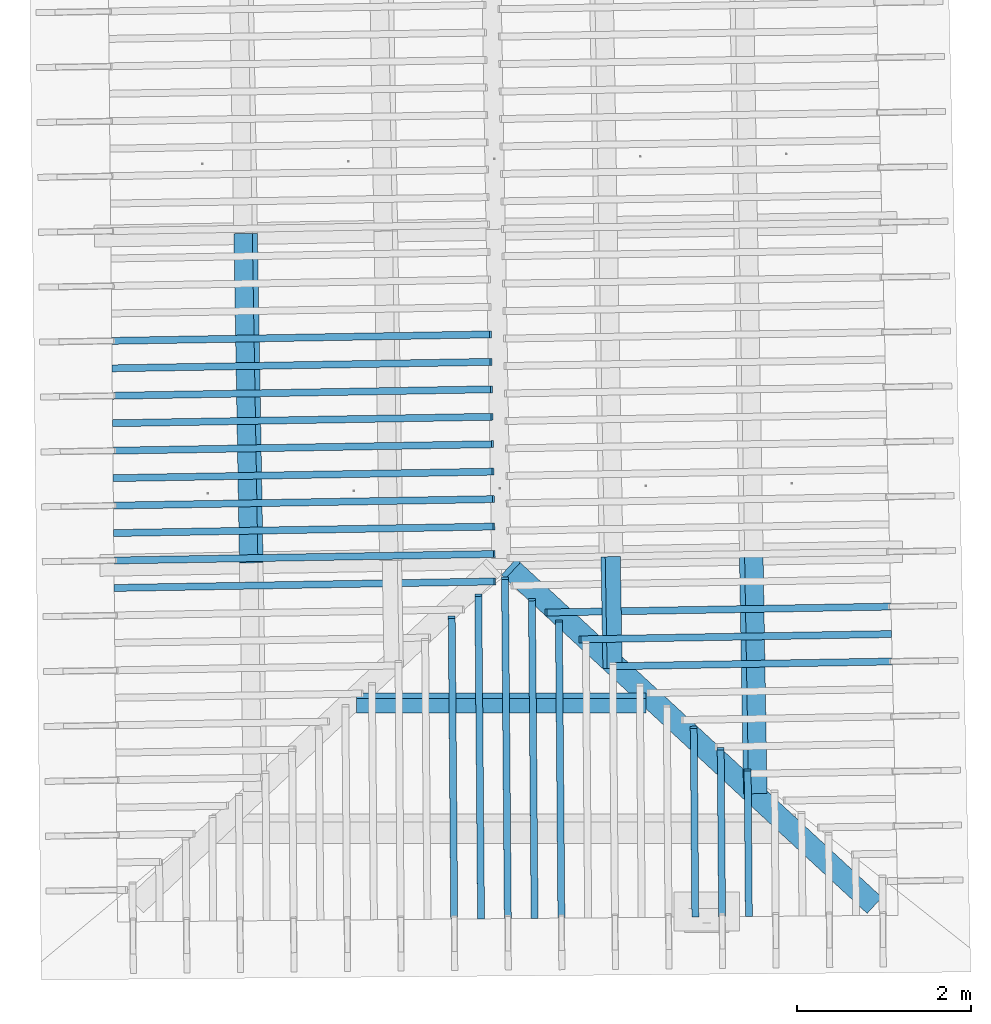
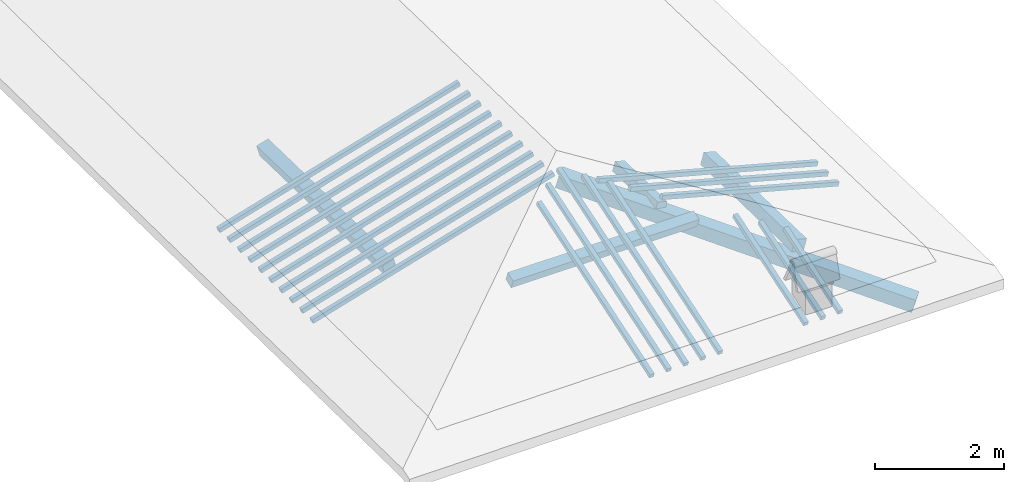
# One storey, part 2 of 19: 22 beams, 4 members, 3 elements without a shape of their own.
"""IFC4 building model written with IfcOpenShell, lengths in metres."""

from ifc_helpers import new_model, entity, si_unit, converted_unit, derived_unit, direction, frame, origin, place, context, subcontext, project, spatial, indexed_curve, outline, extrude, source, transform, mapped, material, type_object, type_shapes, element, aggregate, save


model = new_model("IFC4")

# Units and contexts
model_context = context("Model", 3, precision=1e-05, world=origin(), true_north=direction((6.123233995736766e-17, 1.0)))
body_context = subcontext(model_context, "Body", "Model", "MODEL_VIEW")
ifc_project = project(units=[si_unit("LENGTHUNIT", "METRE"), si_unit("AREAUNIT", "SQUARE_METRE"), si_unit("VOLUMEUNIT", "CUBIC_METRE"), converted_unit("PLANEANGLEUNIT", "DEGREE", entity("IfcPlaneAngleMeasure", 0.017453292519943278), si_unit("PLANEANGLEUNIT", "RADIAN"), dimensions=[0, 0, 0, 0, 0, 0, 0]), derived_unit("THERMALTRANSMITTANCEUNIT", [(si_unit("MASSUNIT", "GRAM", prefix="KILO"), 1), (si_unit("THERMODYNAMICTEMPERATUREUNIT", "KELVIN"), -1), (si_unit("TIMEUNIT", "SECOND"), -3)])], contexts=[model_context])

# Site, building, storey
site_placement = place(None, origin())
site = spatial("IfcSite", under=ifc_project, at=site_placement, CompositionType="ELEMENT")
building_placement = place(site_placement, origin())
building = spatial("IfcBuilding", under=site, at=building_placement, CompositionType="ELEMENT")
storey_placement = place(building_placement, frame((0.0, 0.0, 3.28)))
storey = spatial("IfcBuildingStorey", under=building, at=storey_placement, Name="Livello Copertura", CompositionType="ELEMENT", Elevation=3.28)

# Beam
ifc_material = material(Name="Legno - Legno da costruzione", Category="Legno")
beam_type_1 = type_object("IfcBeamType", Name="Legno:250x250", PredefinedType="BEAM", material=ifc_material)
shared_shape_1 = source(origin(), body_context, "Body", "SweptSolid", [
    extrude(outline(indexed_curve([(-2.9225, -0.12500000000000164), (2.9225, -0.12500000000000164), (2.9225, 0.12500000000000164), (-2.9225, 0.12500000000000164), (-2.9225, -0.12500000000000164)], self_intersect=False)), frame((-0.09349999999999986, 0.0, -0.1250000000000054), z_axis=(0.0, 0.0, 1.0), x_axis=(-1.0, 0.0, 0.0)), (0.0, 0.0, 1.0), 0.2499999999999999),
])
type_shapes(beam_type_1, [shared_shape_1])
beam_1_placement = place(storey_placement, frame((2.0090695639031844, -1.0278532802360452, 0.35358216052505165), z_axis=(0.18601968463087704, -0.17217649990415615, 0.9673427157996195), x_axis=(-0.7099196966505931, 0.6570890001499897, 0.25347203038879224)))
element("IfcBeam", 1, at=beam_1_placement, inside=storey, type_object=beam_type_1, material=ifc_material, Name="Legno:250x250", ObjectType="Legno:250x250", PredefinedType="BEAM", context=body_context, shape_type="MappedRepresentation", body=[
    mapped(shared_shape_1, transform((0.0, 0.0, 0.0), scale=1.0)),
])

# Members
member_type_1 = type_object("IfcMemberType", Name="Legno:220x220", PredefinedType="PURLIN", material=ifc_material)
shared_shape_2 = source(origin(), body_context, "Body", "SweptSolid", [
    extrude(outline(indexed_curve([(-0.11000000000000101, -0.11000000000000051), (0.11000000000000149, -0.11000000000000008), (0.11000000000000139, 0.10999999999999985), (-0.11000000000000164, 0.10999999999999956), (-0.11000000000000101, -0.11000000000000051)], self_intersect=False)), frame((-3.0421074423551655, 4.67700355076878, 3.6469582062155577), z_axis=(0.01708489701561172, -0.9998540424951865, 0.0), x_axis=(-0.9630219859926787, -0.016455533263029815, -0.26891982061526526)), (0.0, 0.0, 1.0), 3.7780000009789068),
])
type_shapes(member_type_1, [shared_shape_2])
member_1_placement = place(storey_placement, frame((0.0, 0.0, -3.28)))
element("IfcMember", 2, at=member_1_placement, inside=storey, type_object=member_type_1, material=ifc_material, Name="Legno:220x220", ObjectType="Legno:220x220", PredefinedType="PURLIN", context=body_context, shape_type="MappedRepresentation", body=[
    mapped(shared_shape_2, transform((0.0, 0.0, 0.0), scale=1.0)),
])
member_type_2 = type_object("IfcMemberType", Name="Legno:220x220", PredefinedType="PURLIN", material=ifc_material)
shared_shape_3 = source(origin(), body_context, "Body", "SweptSolid", [
    extrude(outline(indexed_curve([(-0.11000000000000143, -0.11000000000000014), (0.11000000000000161, -0.11000000000000029), (0.11000000000000157, 0.10999999999999961), (-0.11000000000000146, 0.10999999999999976), (-0.11000000000000143, -0.11000000000000014)], self_intersect=False)), frame((2.7587646780374846, 0.9971322171877381, 3.647129680690416), z_axis=(0.01708489701561066, -0.9998540424951864, 0.0), x_axis=(-0.9630219859926785, -0.016455533263029242, 0.2689198206152659)), (0.0, 0.0, 1.0), 2.747223858990199),
])
type_shapes(member_type_2, [shared_shape_3])
member_2_placement = place(storey_placement, frame((0.0, 0.0, -3.28)))
element("IfcMember", 3, at=member_2_placement, inside=storey, type_object=member_type_2, material=ifc_material, Name="Legno:220x220", ObjectType="Legno:220x220", PredefinedType="PURLIN", context=body_context, shape_type="MappedRepresentation", body=[
    mapped(shared_shape_3, transform((0.0, 0.0, 0.0), scale=1.0)),
])
member_type_3 = type_object("IfcMemberType", Name="Legno:180x180", PredefinedType="PURLIN", material=ifc_material)
shared_shape_4 = source(origin(), body_context, "Body", "SweptSolid", [
    extrude(outline(indexed_curve([(-1.661, -0.09000000000000168), (1.661, -0.09000000000000168), (1.661, 0.09000000000000168), (-1.661, 0.09000000000000168), (-1.661, -0.09000000000000168)], self_intersect=False)), frame((0.0, 0.0, -0.09000000000000546), z_axis=(0.0, 0.0, 1.0), x_axis=(-1.0, 0.0, 0.0)), (0.0, 0.0, 1.0), 0.17999999999999997),
])
type_shapes(member_type_3, [shared_shape_4])
member_3_placement = place(storey_placement, frame((-0.109150931274156, -0.7093865106966336, 0.6793405305954462), z_axis=(0.0, -0.3542910379977155, 0.9351352096860119), x_axis=(1.0, 0.0, 0.0)))
element("IfcMember", 4, at=member_3_placement, inside=storey, type_object=member_type_3, material=ifc_material, Name="Legno:180x180", ObjectType="Legno:180x180", PredefinedType="PURLIN", context=body_context, shape_type="MappedRepresentation", body=[
    mapped(shared_shape_4, transform((0.0, 0.0, 0.0), scale=1.0)),
])
member_type_4 = type_object("IfcMemberType", Name="Legno:180x180", PredefinedType="PURLIN", material=ifc_material)
shared_shape_5 = source(origin(), body_context, "Body", "SweptSolid", [
    extrude(outline(indexed_curve([(-0.09000000000000194, -0.09000000000000007), (0.09000000000000175, -0.08999999999999998), (0.09000000000000169, 0.08999999999999998), (-0.09000000000000187, 0.08999999999999994), (-0.09000000000000194, -0.09000000000000007)], self_intersect=False)), frame((1.145884685497764, 0.9696675918888265, 4.0769343909947935), z_axis=(0.017084897015610626, -0.9998540424951864, 0.0), x_axis=(-0.9630219859926784, -0.01645553326302926, 0.2689198206152662)), (0.0, 0.0, 1.0), 1.2830102786731041),
])
type_shapes(member_type_4, [shared_shape_5])
member_4_placement = place(storey_placement, frame((0.0, 0.0, -3.28)))
element("IfcMember", 5, at=member_4_placement, inside=storey, type_object=member_type_4, material=ifc_material, Name="Legno:180x180", ObjectType="Legno:180x180", PredefinedType="PURLIN", context=body_context, shape_type="MappedRepresentation", body=[
    mapped(shared_shape_5, transform((0.0, 0.0, 0.0), scale=1.0)),
])

# Assembly, beams
assembly_1_placement = place(storey_placement, origin())
assembly_1 = element("IfcElementAssembly", 6, at=assembly_1_placement, inside=storey, Name="Sistema di travi strutturali:Sistema di travi strutturali", ObjectType="Sistema di travi strutturali:Sistema di travi strutturali", AssemblyPlace="NOTDEFINED", PredefinedType="BEAM_GRID")
beam_type_2 = type_object("IfcBeamType", Name="Legno:80x80", PredefinedType="JOIST", material=ifc_material)
shared_shape_6 = source(origin(), body_context, "Body", "SweptSolid", [
    extrude(outline(indexed_curve([(-2.2505, -0.04000000000000169), (2.2505, -0.04000000000000169), (2.2505, 0.04000000000000169), (-2.2505, 0.04000000000000169), (-2.2505, -0.04000000000000169)], self_intersect=False)), frame((0.0, 0.0, -0.040000000000005476), z_axis=(0.0, 0.0, 1.0), x_axis=(-1.0, 0.0, 0.0)), (0.0, 0.0, 1.0), 0.07999999999999997),
])
type_shapes(beam_type_2, [shared_shape_6])
beam_2_placement = place(assembly_1_placement, frame((-2.399820328669917, 3.4829743664786914, 0.6961476384983133), z_axis=(-0.2688805697492536, -0.0045944674406682776, 0.9631625667976582), x_axis=(0.9630219859926786, 0.01645553326302697, 0.26891982061526554)))
beam_2 = element("IfcBeam", 7, at=beam_2_placement, type_object=beam_type_2, material=ifc_material, Name="Legno:80x80", ObjectType="Legno:80x80", PredefinedType="JOIST", context=body_context, shape_type="MappedRepresentation", body=[
    mapped(shared_shape_6, transform((0.0, 0.0, 0.0), scale=1.0)),
])
beam_type_3 = type_object("IfcBeamType", Name="Legno:80x80", PredefinedType="JOIST", material=ifc_material)
shared_shape_7 = source(origin(), body_context, "Body", "SweptSolid", [
    extrude(outline(indexed_curve([(-2.252, -0.04000000000000169), (2.252, -0.04000000000000169), (2.252, 0.04000000000000169), (-2.252, 0.04000000000000169), (-2.252, -0.04000000000000169)], self_intersect=False)), frame((0.0, 0.0, -0.040000000000005476), z_axis=(0.0, 0.0, 1.0), x_axis=(-1.0, 0.0, 0.0)), (0.0, 0.0, 1.0), 0.07999999999999997),
])
type_shapes(beam_type_3, [shared_shape_7])
beam_3_placement = place(assembly_1_placement, frame((-2.395585865635253, 3.1680007390788174, 0.6958272655383883), z_axis=(-0.2688805697492535, -0.004594467440668275, 0.9631625667976583), x_axis=(0.9630219859926786, 0.016455533263026977, 0.2689198206152654)))
beam_3 = element("IfcBeam", 8, at=beam_3_placement, type_object=beam_type_3, material=ifc_material, Name="Legno:80x80", ObjectType="Legno:80x80", PredefinedType="JOIST", context=body_context, shape_type="MappedRepresentation", body=[
    mapped(shared_shape_7, transform((0.0, 0.0, 0.0), scale=1.0)),
])
beam_type_4 = type_object("IfcBeamType", Name="Legno:80x80", PredefinedType="JOIST", material=ifc_material)
shared_shape_8 = source(origin(), body_context, "Body", "SweptSolid", [
    extrude(outline(indexed_curve([(-2.253, -0.04000000000000169), (2.253, -0.04000000000000169), (2.253, 0.04000000000000169), (-2.253, 0.04000000000000169), (-2.253, -0.04000000000000169)], self_intersect=False)), frame((0.0, 0.0, -0.040000000000005476), z_axis=(0.0, 0.0, 1.0), x_axis=(-1.0, 0.0, 0.0)), (0.0, 0.0, 1.0), 0.07999999999999997),
])
type_shapes(beam_type_4, [shared_shape_8])
beam_4_placement = place(assembly_1_placement, frame((-2.391351402600588, 2.8530271116789403, 0.6955068925784609), z_axis=(-0.26888056974925345, -0.004594467440668275, 0.9631625667976583), x_axis=(0.9630219859926787, 0.016455533263026862, 0.26891982061526537)))
beam_4 = element("IfcBeam", 9, at=beam_4_placement, type_object=beam_type_4, material=ifc_material, Name="Legno:80x80", ObjectType="Legno:80x80", PredefinedType="JOIST", context=body_context, shape_type="MappedRepresentation", body=[
    mapped(shared_shape_8, transform((0.0, 0.0, 0.0), scale=1.0)),
])
beam_type_5 = type_object("IfcBeamType", Name="Legno:80x80", PredefinedType="JOIST", material=ifc_material)
shared_shape_9 = source(origin(), body_context, "Body", "SweptSolid", [
    extrude(outline(indexed_curve([(-2.254, -0.04000000000000169), (2.254, -0.04000000000000169), (2.254, 0.04000000000000169), (-2.254, 0.04000000000000169), (-2.254, -0.04000000000000169)], self_intersect=False)), frame((0.0, 0.0, -0.040000000000005476), z_axis=(0.0, 0.0, 1.0), x_axis=(-1.0, 0.0, 0.0)), (0.0, 0.0, 1.0), 0.07999999999999997),
])
type_shapes(beam_type_5, [shared_shape_9])
beam_5_placement = place(assembly_1_placement, frame((-2.387116939565923, 2.538053484279067, 0.6951865196185344), z_axis=(-0.26888056974925356, -0.004594467440668277, 0.9631625667976582), x_axis=(0.9630219859926786, 0.016455533263026883, 0.2689198206152655)))
beam_5 = element("IfcBeam", 10, at=beam_5_placement, type_object=beam_type_5, material=ifc_material, Name="Legno:80x80", ObjectType="Legno:80x80", PredefinedType="JOIST", context=body_context, shape_type="MappedRepresentation", body=[
    mapped(shared_shape_9, transform((0.0, 0.0, 0.0), scale=1.0)),
])
beam_type_6 = type_object("IfcBeamType", Name="Legno:80x80", PredefinedType="JOIST", material=ifc_material)
shared_shape_10 = source(origin(), body_context, "Body", "SweptSolid", [
    extrude(outline(indexed_curve([(-2.2555, -0.04000000000000169), (2.2555, -0.04000000000000169), (2.2555, 0.04000000000000169), (-2.2555, 0.04000000000000169), (-2.2555, -0.04000000000000169)], self_intersect=False)), frame((0.0, 0.0, -0.040000000000005476), z_axis=(0.0, 0.0, 1.0), x_axis=(-1.0, 0.0, 0.0)), (0.0, 0.0, 1.0), 0.07999999999999997),
])
type_shapes(beam_type_6, [shared_shape_10])
beam_6_placement = place(assembly_1_placement, frame((-2.3828824765312584, 2.2230798568791936, 0.6948661466586089), z_axis=(-0.2688805697492536, -0.004594467440668278, 0.9631625667976582), x_axis=(0.9630219859926786, 0.016455533263027004, 0.26891982061526554)))
beam_6 = element("IfcBeam", 11, at=beam_6_placement, type_object=beam_type_6, material=ifc_material, Name="Legno:80x80", ObjectType="Legno:80x80", PredefinedType="JOIST", context=body_context, shape_type="MappedRepresentation", body=[
    mapped(shared_shape_10, transform((0.0, 0.0, 0.0), scale=1.0)),
])
beam_type_7 = type_object("IfcBeamType", Name="Legno:80x80", PredefinedType="JOIST", material=ifc_material)
shared_shape_11 = source(origin(), body_context, "Body", "SweptSolid", [
    extrude(outline(indexed_curve([(-2.2565, -0.04000000000000169), (2.2565, -0.04000000000000169), (2.2565, 0.04000000000000169), (-2.2565, 0.04000000000000169), (-2.2565, -0.04000000000000169)], self_intersect=False)), frame((0.0, 0.0, -0.040000000000005476), z_axis=(0.0, 0.0, 1.0), x_axis=(-1.0, 0.0, 0.0)), (0.0, 0.0, 1.0), 0.07999999999999997),
])
type_shapes(beam_type_7, [shared_shape_11])
beam_7_placement = place(assembly_1_placement, frame((-2.3786480134965933, 1.90810622947932, 0.6945457736986826), z_axis=(-0.2688805697492535, -0.004594467440668277, 0.9631625667976582), x_axis=(0.9630219859926786, 0.016455533263026952, 0.2689198206152654)))
beam_7 = element("IfcBeam", 12, at=beam_7_placement, type_object=beam_type_7, material=ifc_material, Name="Legno:80x80", ObjectType="Legno:80x80", PredefinedType="JOIST", context=body_context, shape_type="MappedRepresentation", body=[
    mapped(shared_shape_11, transform((0.0, 0.0, 0.0), scale=1.0)),
])
beam_type_8 = type_object("IfcBeamType", Name="Legno:80x80", PredefinedType="JOIST", material=ifc_material)
shared_shape_12 = source(origin(), body_context, "Body", "SweptSolid", [
    extrude(outline(indexed_curve([(-2.258, -0.04000000000000169), (2.258, -0.04000000000000169), (2.258, 0.04000000000000169), (-2.258, 0.04000000000000169), (-2.258, -0.04000000000000169)], self_intersect=False)), frame((0.0, 0.0, -0.040000000000005476), z_axis=(0.0, 0.0, 1.0), x_axis=(-1.0, 0.0, 0.0)), (0.0, 0.0, 1.0), 0.07999999999999997),
])
type_shapes(beam_type_8, [shared_shape_12])
beam_8_placement = place(assembly_1_placement, frame((-2.3744135504619286, 1.5931326020794454, 0.6942254007387572), z_axis=(-0.2688805697492536, -0.004594467440668277, 0.9631625667976583), x_axis=(0.9630219859926786, 0.01645553326302695, 0.26891982061526554)))
beam_8 = element("IfcBeam", 13, at=beam_8_placement, type_object=beam_type_8, material=ifc_material, Name="Legno:80x80", ObjectType="Legno:80x80", PredefinedType="JOIST", context=body_context, shape_type="MappedRepresentation", body=[
    mapped(shared_shape_12, transform((0.0, 0.0, 0.0), scale=1.0)),
])
beam_type_9 = type_object("IfcBeamType", Name="Legno:80x80", PredefinedType="JOIST", material=ifc_material)
shared_shape_13 = source(origin(), body_context, "Body", "SweptSolid", [
    extrude(outline(indexed_curve([(-2.259, -0.04000000000000169), (2.259, -0.04000000000000169), (2.259, 0.04000000000000169), (-2.259, 0.04000000000000169), (-2.259, -0.04000000000000169)], self_intersect=False)), frame((0.0, 0.0, -0.040000000000005476), z_axis=(0.0, 0.0, 1.0), x_axis=(-1.0, 0.0, 0.0)), (0.0, 0.0, 1.0), 0.07999999999999997),
])
type_shapes(beam_type_9, [shared_shape_13])
beam_9_placement = place(assembly_1_placement, frame((-2.3701790874272635, 1.2781589746795723, 0.6939050277788292), z_axis=(-0.26888056974925345, -0.004594467440668276, 0.9631625667976583), x_axis=(0.9630219859926786, 0.016455533263026966, 0.26891982061526537)))
beam_9 = element("IfcBeam", 14, at=beam_9_placement, type_object=beam_type_9, material=ifc_material, Name="Legno:80x80", ObjectType="Legno:80x80", PredefinedType="JOIST", context=body_context, shape_type="MappedRepresentation", body=[
    mapped(shared_shape_13, transform((0.0, 0.0, 0.0), scale=1.0)),
])
beam_type_10 = type_object("IfcBeamType", Name="Legno:80x80", PredefinedType="JOIST", material=ifc_material)
shared_shape_14 = source(origin(), body_context, "Body", "SweptSolid", [
    extrude(outline(indexed_curve([(-2.2600000000000002, -0.04000000000000169), (2.2600000000000002, -0.04000000000000169), (2.2600000000000002, 0.04000000000000169), (-2.2600000000000002, 0.04000000000000169), (-2.2600000000000002, -0.04000000000000169)], self_intersect=False)), frame((0.0, 0.0, -0.040000000000005476), z_axis=(0.0, 0.0, 1.0), x_axis=(-1.0, 0.0, 0.0)), (0.0, 0.0, 1.0), 0.07999999999999997),
])
type_shapes(beam_type_10, [shared_shape_14])
beam_10_placement = place(assembly_1_placement, frame((-2.3659446243926, 0.9631853472796985, 0.6935846548189035), z_axis=(-0.26888056974925345, -0.004594467440668274, 0.9631625667976583), x_axis=(0.9630219859926787, 0.016455533263026966, 0.26891982061526537)))
beam_10 = element("IfcBeam", 15, at=beam_10_placement, type_object=beam_type_10, material=ifc_material, Name="Legno:80x80", ObjectType="Legno:80x80", PredefinedType="JOIST", context=body_context, shape_type="MappedRepresentation", body=[
    mapped(shared_shape_14, transform((0.0, 0.0, 0.0), scale=1.0)),
])
beam_type_11 = type_object("IfcBeamType", Name="Legno:80x80", PredefinedType="JOIST", material=ifc_material)
shared_shape_15 = source(origin(), body_context, "Body", "SweptSolid", [
    extrude(outline(indexed_curve([(-2.2615, -0.04000000000000169), (2.2615, -0.04000000000000169), (2.2615, 0.04000000000000169), (-2.2615, 0.04000000000000169), (-2.2615, -0.04000000000000169)], self_intersect=False)), frame((0.0, 0.0, -0.040000000000005476), z_axis=(0.0, 0.0, 1.0), x_axis=(-1.0, 0.0, 0.0)), (0.0, 0.0, 1.0), 0.07999999999999997),
])
type_shapes(beam_type_11, [shared_shape_15])
beam_11_placement = place(assembly_1_placement, frame((-2.3617101613579345, 0.648211719879825, 0.693264281858978), z_axis=(-0.26888056974925345, -0.004594467440668274, 0.9631625667976583), x_axis=(0.9630219859926786, 0.016455533263026977, 0.26891982061526537)))
beam_11 = element("IfcBeam", 16, at=beam_11_placement, type_object=beam_type_11, material=ifc_material, Name="Legno:80x80", ObjectType="Legno:80x80", PredefinedType="JOIST", context=body_context, shape_type="MappedRepresentation", body=[
    mapped(shared_shape_15, transform((0.0, 0.0, 0.0), scale=1.0)),
])
aggregate(assembly_1, [beam_2, beam_3, beam_4, beam_5, beam_6, beam_7, beam_8, beam_9, beam_10, beam_11])

assembly_2_placement = place(storey_placement, origin())
assembly_2 = element("IfcElementAssembly", 17, at=assembly_2_placement, inside=storey, Name="Sistema di travi strutturali:Sistema di travi strutturali", ObjectType="Sistema di travi strutturali:Sistema di travi strutturali", AssemblyPlace="NOTDEFINED", PredefinedType="BEAM_GRID")
beam_type_12 = type_object("IfcBeamType", Name="Legno:80x80", PredefinedType="JOIST", material=ifc_material)
shared_shape_16 = source(origin(), body_context, "Body", "SweptSolid", [
    extrude(outline(indexed_curve([(-1.652, -0.04000000000000169), (1.652, -0.04000000000000169), (1.652, 0.04000000000000169), (-1.652, 0.04000000000000169), (-1.652, -0.04000000000000169)], self_intersect=False)), frame((0.0, 0.0, -0.040000000000005476), z_axis=(0.0, 0.0, 1.0), x_axis=(-1.0, 0.0, 0.0)), (0.0, 0.0, 1.0), 0.07999999999999997),
])
type_shapes(beam_type_12, [shared_shape_16])
beam_12_placement = place(assembly_2_placement, frame((2.7747250914172046, -0.2600681485875779, 0.5243462023108555), z_axis=(0.26888056974925345, 0.0045944674406682776, 0.9631625667976583), x_axis=(-0.9630219859926786, -0.016455533263027868, 0.26891982061526537)))
beam_12 = element("IfcBeam", 18, at=beam_12_placement, type_object=beam_type_12, material=ifc_material, Name="Legno:80x80", ObjectType="Legno:80x80", PredefinedType="JOIST", context=body_context, shape_type="MappedRepresentation", body=[
    mapped(shared_shape_16, transform((0.0, 0.0, 0.0), scale=1.0)),
])
beam_type_13 = type_object("IfcBeamType", Name="Legno:80x80", PredefinedType="JOIST", material=ifc_material)
shared_shape_17 = source(origin(), body_context, "Body", "SweptSolid", [
    extrude(outline(indexed_curve([(-1.8510000000000002, -0.04000000000000169), (1.8510000000000002, -0.04000000000000169), (1.8510000000000002, 0.04000000000000169), (-1.8510000000000002, 0.04000000000000169), (-1.8510000000000002, -0.04000000000000169)], self_intersect=False)), frame((0.0, 0.0, -0.040000000000005476), z_axis=(0.0, 0.0, 1.0), x_axis=(-1.0, 0.0, 0.0)), (0.0, 0.0, 1.0), 0.07999999999999997),
])
type_shapes(beam_type_13, [shared_shape_17])
beam_13_placement = place(assembly_2_placement, frame((2.575711566317611, 0.05157721281071862, 0.5784170594495001), z_axis=(0.2688805697492534, 0.004594467440668275, 0.9631625667976583), x_axis=(-0.9630219859926786, -0.016455533263027875, 0.2689198206152653)))
beam_13 = element("IfcBeam", 19, at=beam_13_placement, type_object=beam_type_13, material=ifc_material, Name="Legno:80x80", ObjectType="Legno:80x80", PredefinedType="JOIST", context=body_context, shape_type="MappedRepresentation", body=[
    mapped(shared_shape_17, transform((0.0, 0.0, 0.0), scale=1.0)),
])
beam_type_14 = type_object("IfcBeamType", Name="Legno:80x80", PredefinedType="JOIST", material=ifc_material)
shared_shape_18 = source(origin(), body_context, "Body", "SweptSolid", [
    extrude(outline(indexed_curve([(-2.0500000000000003, -0.04000000000000169), (2.0500000000000003, -0.04000000000000169), (2.0500000000000003, 0.04000000000000169), (-2.0500000000000003, 0.04000000000000169), (-2.0500000000000003, -0.04000000000000169)], self_intersect=False)), frame((0.0, 0.0, -0.040000000000005476), z_axis=(0.0, 0.0, 1.0), x_axis=(-1.0, 0.0, 0.0)), (0.0, 0.0, 1.0), 0.07999999999999997),
])
type_shapes(beam_type_14, [shared_shape_18])
beam_14_placement = place(assembly_2_placement, frame((2.376698041218017, 0.3632225742090152, 0.6324879165881454), z_axis=(0.2688805697492535, 0.004594467440668277, 0.9631625667976583), x_axis=(-0.9630219859926786, -0.016455533263027875, 0.2689198206152654)))
beam_14 = element("IfcBeam", 20, at=beam_14_placement, type_object=beam_type_14, material=ifc_material, Name="Legno:80x80", ObjectType="Legno:80x80", PredefinedType="JOIST", context=body_context, shape_type="MappedRepresentation", body=[
    mapped(shared_shape_18, transform((0.0, 0.0, 0.0), scale=1.0)),
])
aggregate(assembly_2, [beam_12, beam_13, beam_14])

assembly_3_placement = place(storey_placement, origin())
assembly_3 = element("IfcElementAssembly", 21, at=assembly_3_placement, inside=storey, Name="Sistema di travi strutturali:Sistema di travi strutturali", ObjectType="Sistema di travi strutturali:Sistema di travi strutturali", AssemblyPlace="NOTDEFINED", PredefinedType="BEAM_GRID")
beam_type_15 = type_object("IfcBeamType", Name="Legno:80x80", PredefinedType="JOIST", material=ifc_material)
shared_shape_19 = source(origin(), body_context, "Body", "SweptSolid", [
    extrude(outline(indexed_curve([(-0.8825, -0.04000000000000169), (0.8825, -0.04000000000000169), (0.8825, 0.04000000000000169), (-0.8825, 0.04000000000000169), (-0.8825, -0.04000000000000169)], self_intersect=False)), frame((0.0, 0.0, -0.040000000000005476), z_axis=(0.0, 0.0, 1.0), x_axis=(-1.0, 0.0, 0.0)), (0.0, 0.0, 1.0), 0.07999999999999997),
])
type_shapes(beam_type_15, [shared_shape_19])
beam_15_placement = place(assembly_3_placement, frame((2.724421063231999, -2.3112118465310294, 0.2626386713568529), z_axis=(0.0033933227624359905, -0.3255504700615088, 0.9455185755993166), x_axis=(-0.00793235019477967, 0.9454855083215803, 0.3255675527049191)))
beam_15 = element("IfcBeam", 22, at=beam_15_placement, type_object=beam_type_15, material=ifc_material, Name="Legno:80x80", ObjectType="Legno:80x80", PredefinedType="JOIST", context=body_context, shape_type="MappedRepresentation", body=[
    mapped(shared_shape_19, transform((0.0, 0.0, 0.0), scale=1.0)),
])
beam_type_16 = type_object("IfcBeamType", Name="Legno:80x80", PredefinedType="JOIST", material=ifc_material)
shared_shape_20 = source(origin(), body_context, "Body", "SweptSolid", [
    extrude(outline(indexed_curve([(-1.0130000000000001, -0.04000000000000169), (1.0130000000000001, -0.04000000000000169), (1.0130000000000001, 0.04000000000000169), (-1.0130000000000001, 0.04000000000000169), (-1.0130000000000001, -0.04000000000000169)], self_intersect=False)), frame((0.0, 0.0, -0.040000000000005476), z_axis=(0.0, 0.0, 1.0), x_axis=(-1.0, 0.0, 0.0)), (0.0, 0.0, 1.0), 0.07999999999999997),
])
type_shapes(beam_type_16, [shared_shape_20])
beam_16_placement = place(assembly_3_placement, frame((2.416096942706781, -2.1904242467161072, 0.30533344668492923), z_axis=(0.0033933227624359896, -0.32555047006150867, 0.9455185755993167), x_axis=(-0.00793235019477956, 0.9454855083215804, 0.325567552704919)))
beam_16 = element("IfcBeam", 23, at=beam_16_placement, type_object=beam_type_16, material=ifc_material, Name="Legno:80x80", ObjectType="Legno:80x80", PredefinedType="JOIST", context=body_context, shape_type="MappedRepresentation", body=[
    mapped(shared_shape_20, transform((0.0, 0.0, 0.0), scale=1.0)),
])
beam_type_17 = type_object("IfcBeamType", Name="Legno:80x80", PredefinedType="JOIST", material=ifc_material)
shared_shape_21 = source(origin(), body_context, "Body", "SweptSolid", [
    extrude(outline(indexed_curve([(-1.1435000000000002, -0.04000000000000169), (1.1435000000000002, -0.04000000000000169), (1.1435000000000002, 0.04000000000000169), (-1.1435000000000002, 0.04000000000000169), (-1.1435000000000002, -0.04000000000000169)], self_intersect=False)), frame((0.0, 0.0, -0.040000000000005476), z_axis=(0.0, 0.0, 1.0), x_axis=(-1.0, 0.0, 0.0)), (0.0, 0.0, 1.0), 0.07999999999999997),
])
type_shapes(beam_type_17, [shared_shape_21])
beam_17_placement = place(assembly_3_placement, frame((2.1077728221815644, -2.069636646901185, 0.34802822201300476), z_axis=(0.0033933227624359905, -0.3255504700615087, 0.9455185755993166), x_axis=(-0.007932350194779596, 0.9454855083215803, 0.32556755270491905)))
beam_17 = element("IfcBeam", 24, at=beam_17_placement, type_object=beam_type_17, material=ifc_material, Name="Legno:80x80", ObjectType="Legno:80x80", PredefinedType="JOIST", context=body_context, shape_type="MappedRepresentation", body=[
    mapped(shared_shape_21, transform((0.0, 0.0, 0.0), scale=1.0)),
])
beam_type_18 = type_object("IfcBeamType", Name="Legno:80x80", PredefinedType="JOIST", material=ifc_material)
shared_shape_22 = source(origin(), body_context, "Body", "SweptSolid", [
    extrude(outline(indexed_curve([(-1.7965000000000002, -0.04000000000000169), (1.7965000000000002, -0.04000000000000169), (1.7965000000000002, 0.04000000000000169), (-1.7965000000000002, 0.04000000000000169), (-1.7965000000000002, -0.04000000000000169)], self_intersect=False)), frame((0.0, 0.0, -0.040000000000005476), z_axis=(0.0, 0.0, 1.0), x_axis=(-1.0, 0.0, 0.0)), (0.0, 0.0, 1.0), 0.07999999999999997),
])
type_shapes(beam_type_18, [shared_shape_22])
beam_18_placement = place(assembly_3_placement, frame((0.5661522195554801, -1.4656986478265766, 0.5615020986533854), z_axis=(0.0033933227624359896, -0.3255504700615087, 0.9455185755993166), x_axis=(-0.00793235019477957, 0.9454855083215803, 0.32556755270491905)))
beam_18 = element("IfcBeam", 25, at=beam_18_placement, type_object=beam_type_18, material=ifc_material, Name="Legno:80x80", ObjectType="Legno:80x80", PredefinedType="JOIST", context=body_context, shape_type="MappedRepresentation", body=[
    mapped(shared_shape_22, transform((0.0, 0.0, 0.0), scale=1.0)),
])
beam_type_19 = type_object("IfcBeamType", Name="Legno:80x80", PredefinedType="JOIST", material=ifc_material)
shared_shape_23 = source(origin(), body_context, "Body", "SweptSolid", [
    extrude(outline(indexed_curve([(-1.927, -0.04000000000000169), (1.927, -0.04000000000000169), (1.927, 0.04000000000000169), (-1.927, 0.04000000000000169), (-1.927, -0.04000000000000169)], self_intersect=False)), frame((0.0, 0.0, -0.040000000000005476), z_axis=(0.0, 0.0, 1.0), x_axis=(-1.0, 0.0, 0.0)), (0.0, 0.0, 1.0), 0.07999999999999997),
])
type_shapes(beam_type_19, [shared_shape_23])
beam_19_placement = place(assembly_3_placement, frame((0.2578280990302629, -1.3449110480116548, 0.6041968739814627), z_axis=(0.003393322762435988, -0.32555047006150856, 0.9455185755993167), x_axis=(-0.007932350194779565, 0.9454855083215804, 0.3255675527049189)))
beam_19 = element("IfcBeam", 26, at=beam_19_placement, type_object=beam_type_19, material=ifc_material, Name="Legno:80x80", ObjectType="Legno:80x80", PredefinedType="JOIST", context=body_context, shape_type="MappedRepresentation", body=[
    mapped(shared_shape_23, transform((0.0, 0.0, 0.0), scale=1.0)),
])
beam_type_20 = type_object("IfcBeamType", Name="Legno:80x80", PredefinedType="JOIST", material=ifc_material)
shared_shape_24 = source(origin(), body_context, "Body", "SweptSolid", [
    extrude(outline(indexed_curve([(-2.0575, -0.04000000000000169), (2.0575, -0.04000000000000169), (2.0575, 0.04000000000000169), (-2.0575, 0.04000000000000169), (-2.0575, -0.04000000000000169)], self_intersect=False)), frame((0.0, 0.0, -0.040000000000005476), z_axis=(0.0, 0.0, 1.0), x_axis=(-1.0, 0.0, 0.0)), (0.0, 0.0, 1.0), 0.07999999999999997),
])
type_shapes(beam_type_20, [shared_shape_24])
beam_20_placement = place(assembly_3_placement, frame((-0.05049602149495375, -1.2241234481967331, 0.6468916493095388), z_axis=(0.00339332276243599, -0.3255504700615086, 0.9455185755993168), x_axis=(-0.00793235019477957, 0.9454855083215803, 0.325567552704919)))
beam_20 = element("IfcBeam", 27, at=beam_20_placement, type_object=beam_type_20, material=ifc_material, Name="Legno:80x80", ObjectType="Legno:80x80", PredefinedType="JOIST", context=body_context, shape_type="MappedRepresentation", body=[
    mapped(shared_shape_24, transform((0.0, 0.0, 0.0), scale=1.0)),
])
beam_type_21 = type_object("IfcBeamType", Name="Legno:80x80", PredefinedType="JOIST", material=ifc_material)
shared_shape_25 = source(origin(), body_context, "Body", "SweptSolid", [
    extrude(outline(indexed_curve([(-1.9570000000000003, -0.04000000000000169), (1.9570000000000003, -0.04000000000000169), (1.9570000000000003, 0.04000000000000169), (-1.9570000000000003, 0.04000000000000169), (-1.9570000000000003, -0.04000000000000169)], self_intersect=False)), frame((0.0, 0.0, -0.040000000000005476), z_axis=(0.0, 0.0, 1.0), x_axis=(-1.0, 0.0, 0.0)), (0.0, 0.0, 1.0), 0.07999999999999997),
])
type_shapes(beam_type_21, [shared_shape_25])
beam_21_placement = place(assembly_3_placement, frame((-0.35698876003894636, -1.3216248902081118, 0.6144209900495697), z_axis=(0.00339332276243599, -0.3255504700615086, 0.9455185755993168), x_axis=(-0.00793235019477958, 0.9454855083215803, 0.325567552704919)))
beam_21 = element("IfcBeam", 28, at=beam_21_placement, type_object=beam_type_21, material=ifc_material, Name="Legno:80x80", ObjectType="Legno:80x80", PredefinedType="JOIST", context=body_context, shape_type="MappedRepresentation", body=[
    mapped(shared_shape_25, transform((0.0, 0.0, 0.0), scale=1.0)),
])
beam_type_22 = type_object("IfcBeamType", Name="Legno:80x80", PredefinedType="JOIST", material=ifc_material)
shared_shape_26 = source(origin(), body_context, "Body", "SweptSolid", [
    extrude(outline(indexed_curve([(-1.824, -0.04000000000000169), (1.824, -0.04000000000000169), (1.824, 0.04000000000000169), (-1.824, 0.04000000000000169), (-1.824, -0.04000000000000169)], self_intersect=False)), frame((0.0, 0.0, -0.040000000000005476), z_axis=(0.0, 0.0, 1.0), x_axis=(-1.0, 0.0, 0.0)), (0.0, 0.0, 1.0), 0.07999999999999997),
])
type_shapes(beam_type_22, [shared_shape_26])
beam_22_placement = place(assembly_3_placement, frame((-0.6632223366272184, -1.450016783022206, 0.5713135432542269), z_axis=(0.0033933227624359896, -0.32555047006150856, 0.9455185755993168), x_axis=(-0.00793235019477957, 0.9454855083215804, 0.32556755270491894)))
beam_22 = element("IfcBeam", 29, at=beam_22_placement, type_object=beam_type_22, material=ifc_material, Name="Legno:80x80", ObjectType="Legno:80x80", PredefinedType="JOIST", context=body_context, shape_type="MappedRepresentation", body=[
    mapped(shared_shape_26, transform((0.0, 0.0, 0.0), scale=1.0)),
])
aggregate(assembly_3, [beam_15, beam_16, beam_17, beam_18, beam_19, beam_20, beam_21, beam_22])

save(model, "model.ifc")
